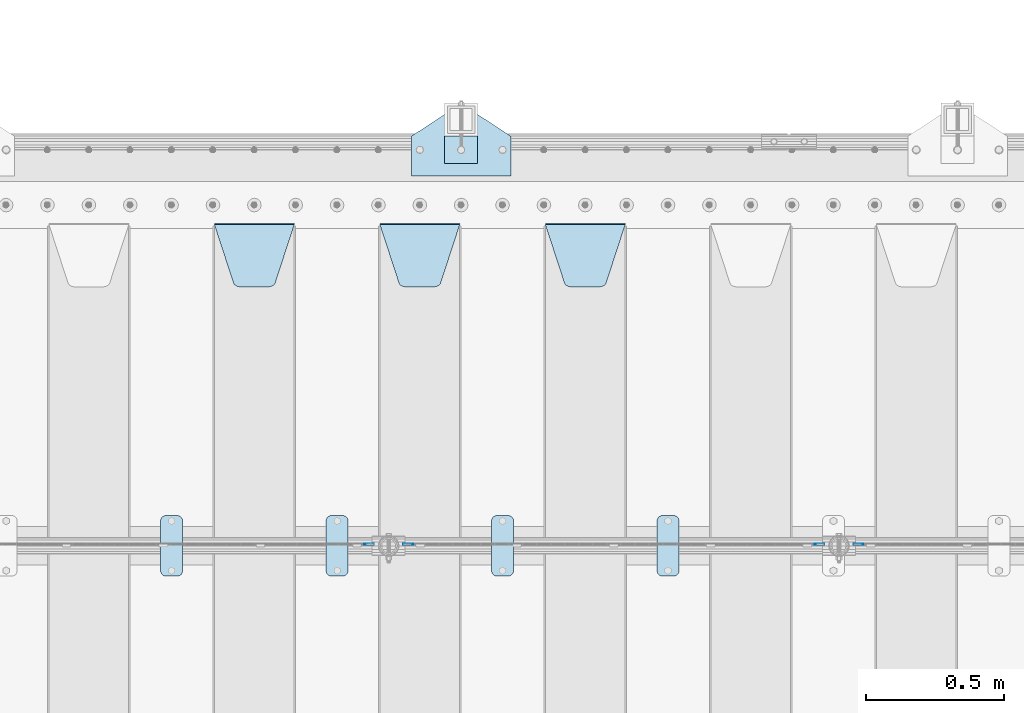
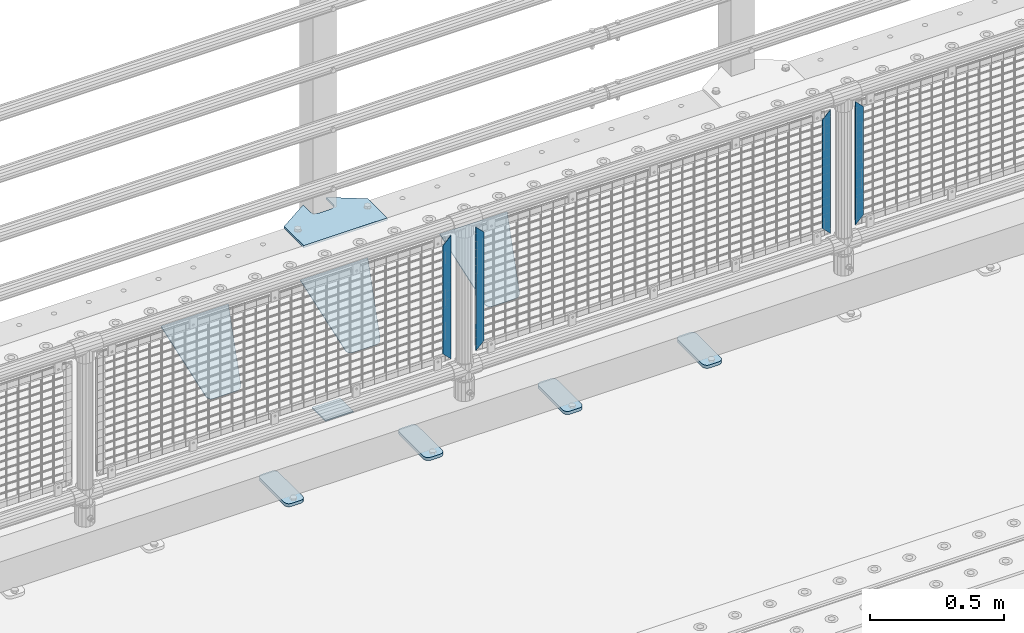
# One storey, part 232 of 270: 13 plates.
"""IFC2X3 building model written with IfcOpenShell, lengths in millimetres."""

import ifcopenshell
import ifcopenshell.guid

model = None  # the IFC model being written
_history = None  # IfcOwnerHistory: only IFC2X3 demands one
_inside = {}  # id of a spatial element -> (the spatial element, [elements in it])
_under = {}  # id of a project, library or spatial element -> (it, [spatial elements below it])
_declared = {}  # id of a project -> (the project, [libraries it declares])
_typed = {}  # id of a type object -> (the type object, [elements of that type])
_made_of = {}  # id of a material, layer set ... -> (it, [elements and type objects made of it])


def new_model(schema):
    """Start an empty IFC model of exactly this schema.

    Asked for "IFC4X3", IfcOpenShell would pick the latest addendum, in which some entities
    have other attributes; the version numbers below select the first issue.
    IFC2X3 requires an IfcOwnerHistory on every rooted entity: one is made here for all.
    """
    global model, _history
    if schema == "IFC4X3":
        model = ifcopenshell.file(schema_version=(4, 3, 0, 0))
    else:
        model = ifcopenshell.file(schema=schema)
    _inside.clear()
    _under.clear()
    _declared.clear()
    _typed.clear()
    _made_of.clear()
    _history = None
    if model.schema == "IFC2X3":
        org = make("IfcOrganization", Name="unknown")
        user = make(
            "IfcPersonAndOrganization",
            ThePerson=make("IfcPerson", FamilyName="unknown"),
            TheOrganization=org,
        )
        app = make(
            "IfcApplication",
            ApplicationDeveloper=org,
            Version="unknown",
            ApplicationFullName="unknown",
            ApplicationIdentifier="unknown",
        )
        _history = make(
            "IfcOwnerHistory",
            OwningUser=user,
            OwningApplication=app,
            ChangeAction="ADDED",
            CreationDate=0,
        )
    return model


def make(cls, **values):
    """One entity of the class cls with the attributes given. An attribute that is None is left unset."""
    return model.create_entity(
        cls, **{name: value for name, value in values.items() if value is not None}
    )


def rooted(cls, **values):
    """An entity with a GlobalId (a new one), such as an element, a storey or a relation."""
    return make(cls, GlobalId=ifcopenshell.guid.new(), OwnerHistory=_history, **values)


def si_unit(unit_type, name, prefix=None):
    """IfcSIUnit, for example si_unit("LENGTHUNIT", "METRE", prefix="MILLI")."""
    return make("IfcSIUnit", UnitType=unit_type, Prefix=prefix, Name=name)


def assignment(units):
    """IfcUnitAssignment: the units of a project."""
    return None if units is None else make("IfcUnitAssignment", Units=units)


def point(xyz):
    """IfcCartesianPoint."""
    return None if xyz is None else make("IfcCartesianPoint", Coordinates=xyz)


def direction(xyz):
    """IfcDirection."""
    return None if xyz is None else make("IfcDirection", DirectionRatios=xyz)


def frame(location, z_axis=None, x_axis=None):
    """IfcAxis2Placement3D, a coordinate frame: its origin and axes. An axis left out is left unset."""
    return make(
        "IfcAxis2Placement3D",
        Location=point(location),
        Axis=direction(z_axis),
        RefDirection=direction(x_axis),
    )


def origin_with_axes():
    """The frame at (0, 0, 0) with the z axis (0, 0, 1) and the x axis (1, 0, 0) written out."""
    return frame((0.0, 0.0, 0.0), z_axis=(0.0, 0.0, 1.0), x_axis=(1.0, 0.0, 0.0))


def place(relative_to, where):
    """IfcLocalPlacement: puts the frame where relative to a parent placement (None: the world)."""
    return make(
        "IfcLocalPlacement", PlacementRelTo=relative_to, RelativePlacement=where
    )


def context(
    kind, dimensions, precision=None, world=None, true_north=None, identifier=None
):
    """IfcGeometricRepresentationContext, for example the 3D "Model" context."""
    return make(
        "IfcGeometricRepresentationContext",
        ContextIdentifier=identifier,
        ContextType=kind,
        CoordinateSpaceDimension=dimensions,
        Precision=precision,
        WorldCoordinateSystem=world,
        TrueNorth=true_north,
    )


def subcontext(parent, identifier, kind, view, scale=None):
    """IfcGeometricRepresentationSubContext, for example "Body" below "Model"."""
    return make(
        "IfcGeometricRepresentationSubContext",
        ContextIdentifier=identifier,
        ContextType=kind,
        ParentContext=parent,
        TargetScale=scale,
        TargetView=view,
    )


def project(units=None, contexts=None):
    """IfcProject with its units and contexts."""
    return rooted(
        "IfcProject",
        Name="project",
        RepresentationContexts=contexts,
        UnitsInContext=assignment(units),
    )


def spatial(cls, under=None, at=None, **own):
    """A site, building, storey or space (cls), placed at a placement, below another one or the project."""
    s = rooted(cls, ObjectPlacement=at, **own)
    if under is not None:
        _under.setdefault(under.id(), (under, []))[1].append(s)
    return s


def faces_of(points, faces, orient=None, outer=None):
    """IfcFace entities. A face is a list of loops; a loop is a list of indices into points, from 0.

    orient and outer hold one flag for each loop. By default every Orientation is true, the
    first loop of a face is its IfcFaceOuterBound and the others are IfcFaceBound.
    """
    made = []
    for i, loops in enumerate(faces):
        bounds = []
        for j, loop in enumerate(loops):
            is_outer = j == 0 if outer is None else outer[i][j]
            bounds.append(
                make(
                    "IfcFaceOuterBound" if is_outer else "IfcFaceBound",
                    Bound=make("IfcPolyLoop", Polygon=[points[k] for k in loop]),
                    Orientation=True if orient is None else orient[i][j],
                )
            )
        made.append(make("IfcFace", Bounds=bounds))
    return made


def faceted_brep(points, faces, orient=None, outer=None, voids=None):
    """IfcFacetedBrep: a solid bounded by flat faces; with voids (closed shells), ...WithVoids."""
    shared = [point(p) for p in points]
    hull = make("IfcClosedShell", CfsFaces=faces_of(shared, faces, orient, outer))
    if voids is None:
        return make("IfcFacetedBrep", Outer=hull)
    return make(
        "IfcFacetedBrepWithVoids",
        Outer=hull,
        Voids=[
            make(cls, CfsFaces=faces_of(shared, fs, o, b)) for cls, fs, o, b in voids
        ],
    )


def shape(context_of_items, identifier, shape_type, items):
    """IfcShapeRepresentation: the items that make up one representation, for example the "Body"."""
    return make(
        "IfcShapeRepresentation",
        ContextOfItems=context_of_items,
        RepresentationIdentifier=identifier,
        RepresentationType=shape_type,
        Items=items,
    )


def material(Name=None, Category=None):
    """IfcMaterial."""
    return make("IfcMaterial", Name=Name, Category=Category)


def made_of(thing, what):
    """Note that an element or type object is made of a material, layer set ...; save() writes the relation."""
    if what is not None:
        _made_of.setdefault(what.id(), (what, []))[1].append(thing)
    return thing


def type_object(cls, material=None, **own):
    """A type object (cls), such as IfcWallType, which elements share."""
    return made_of(rooted(cls, **own), material)


def element(
    cls,
    number,
    at=None,
    inside=None,
    cuts=None,
    type_object=None,
    material=None,
    context=None,
    identifier="Body",
    shape_type=None,
    held_by="IfcProductDefinitionShape",
    body=None,
    shapes=None,
    **own,
):
    """One element of the class cls, such as IfcWall. Its Tag is "e" and its number.

    at: its placement. inside: the storey or other place that contains it. cuts: it is an
    opening in that element (IfcRelVoidsElement). A single representation is given by context,
    identifier, shape_type and body (its items); several are given by shapes. held_by: the class
    of the entity that holds the representations. save() writes the other relations.
    """
    e = rooted(cls, Tag="e%d" % number, ObjectPlacement=at, **own)
    if body is not None:
        shapes = [shape(context, identifier, shape_type, body)]
    if shapes is not None:
        e.Representation = make(held_by, Representations=shapes)
    if inside is not None:
        _inside.setdefault(inside.id(), (inside, []))[1].append(e)
    if cuts is not None:
        rooted(
            "IfcRelVoidsElement", RelatingBuildingElement=cuts, RelatedOpeningElement=e
        )
    if type_object is not None:
        _typed.setdefault(type_object.id(), (type_object, []))[1].append(e)
    return made_of(e, material)


def aggregate(whole, parts):
    """IfcRelAggregates: a whole, such as a stair, and the parts it consists of."""
    return rooted("IfcRelAggregates", RelatingObject=whole, RelatedObjects=parts)


def save(model, path):
    """Write the relations noted so far, then the file.

    IfcRelAggregates (storeys below a building ...), IfcRelContainedInSpatialStructure (elements
    in a storey), IfcRelDefinesByType, IfcRelAssociatesMaterial and IfcRelDeclares: one each for
    every whole, place, type object, material and project.
    """
    for whole, parts in _under.values():
        aggregate(whole, parts)
    for where, things in _inside.values():
        rooted(
            "IfcRelContainedInSpatialStructure",
            RelatedElements=things,
            RelatingStructure=where,
        )
    for kind, things in _typed.values():
        rooted("IfcRelDefinesByType", RelatedObjects=things, RelatingType=kind)
    for what, things in _made_of.values():
        rooted("IfcRelAssociatesMaterial", RelatedObjects=things, RelatingMaterial=what)
    for by, libraries in _declared.values():
        rooted("IfcRelDeclares", RelatingContext=by, RelatedDefinitions=libraries)
    model.write(path)


model = new_model("IFC2X3")

# Units and contexts
model_context = context("Model", 3, precision=1e-05, world=origin_with_axes())
body_context = subcontext(model_context, "Body", "Model", "MODEL_VIEW")
ifc_project = project(units=[si_unit("LENGTHUNIT", "METRE", prefix="MILLI"), si_unit("AREAUNIT", "SQUARE_METRE"), si_unit("VOLUMEUNIT", "CUBIC_METRE"), si_unit("MASSUNIT", "GRAM", prefix="KILO"), si_unit("TIMEUNIT", "SECOND"), si_unit("PLANEANGLEUNIT", "RADIAN"), si_unit("SOLIDANGLEUNIT", "STERADIAN"), si_unit("THERMODYNAMICTEMPERATUREUNIT", "DEGREE_CELSIUS"), si_unit("LUMINOUSINTENSITYUNIT", "LUMEN")], contexts=[model_context])

# Site, building, storey
site_placement = place(None, origin_with_axes())
site = spatial("IfcSite", under=ifc_project, at=site_placement, CompositionType="ELEMENT")
building_placement = place(site_placement, origin_with_axes())
building = spatial("IfcBuilding", under=site, at=building_placement, Name="Standard", CompositionType="ELEMENT")
storey_placement = place(building_placement, origin_with_axes())
storey = spatial("IfcBuildingStorey", under=building, at=storey_placement, Name="Undefined", CompositionType="ELEMENT", Elevation=0.0)

# Plates
ifc_material_1 = material(Name="STEEL/S355J2")
plate_type_1 = type_object("IfcPlateType", PredefinedType="NOTDEFINED")
plate_1_placement = place(storey_placement, frame((3970.0, -14995.0, 5.00000000004911), z_axis=(0.0, 1.0, 0.0), x_axis=(1.0, 0.0, 0.0)))
element("IfcPlate", 1, at=plate_1_placement, inside=storey, type_object=plate_type_1, material=ifc_material_1, context=body_context, shape_type="Brep", body=[
    faceted_brep([(0.0, -5.0, 0.0), (2.31396552408114e-06, -5.0, 145.0), (2.31396552408114e-06, 5.0, 145.0), (0.0, 5.0, 0.0), (130.0, -5.0, 230.0), (130.0, 5.0, 230.0), (130.0, -5.0, 180.0), (130.0, 5.0, 180.0), (130.48036798992, -5.0, 175.122741949597), (130.48036798992, 5.0, 175.122741949597), (131.903011687216, -5.0, 170.432914190873), (131.903011687216, 5.0, 170.432914190873), (134.213259692435, -5.0, 166.11074417451), (134.213259692435, 5.0, 166.11074417451), (137.322330470335, -5.0, 162.322330470337), (137.322330470335, 5.0, 162.322330470337), (141.110744174512, -5.0, 159.213259692437), (141.110744174512, 5.0, 159.213259692437), (145.432914190871, -5.0, 156.903011687218), (145.432914190871, 5.0, 156.903011687218), (150.122741949595, -5.0, 155.48036798992), (150.122741949595, 5.0, 155.48036798992), (155.0, -5.0, 155.0), (155.0, 5.0, 155.0), (205.0, -5.0, 155.0), (205.0, 5.0, 155.0), (209.877258050405, -5.0, 155.48036798992), (209.877258050405, 5.0, 155.48036798992), (214.567085809129, -5.0, 156.903011687218), (214.567085809129, 5.0, 156.903011687218), (218.889255825488, -5.0, 159.213259692437), (218.889255825488, 5.0, 159.213259692437), (222.677669529665, -5.0, 162.322330470337), (222.677669529665, 5.0, 162.322330470337), (225.786740307565, -5.0, 166.11074417451), (225.786740307565, 5.0, 166.11074417451), (228.096988312784, -5.0, 170.432914190873), (228.096988312784, 5.0, 170.432914190873), (229.51963201008, -5.0, 175.122741949597), (229.51963201008, 5.0, 175.122741949597), (230.0, -5.0, 180.0), (230.0, 5.0, 180.0), (230.0, -5.0, 230.0), (230.0, 5.0, 230.0), (360.0, -5.0, 145.0), (360.0, 5.0, 145.0), (360.0, -5.0, -7.27595761418343e-12), (360.0, 5.0, -7.27595761418343e-12)], [[[0, 1, 2, 3]], [[1, 4, 5, 2]], [[4, 6, 7, 5]], [[6, 8, 9, 7]], [[8, 10, 11, 9]], [[10, 12, 13, 11]], [[12, 14, 15, 13]], [[14, 16, 17, 15]], [[16, 18, 19, 17]], [[18, 20, 21, 19]], [[20, 22, 23, 21]], [[22, 24, 25, 23]], [[24, 26, 27, 25]], [[26, 28, 29, 27]], [[28, 30, 31, 29]], [[30, 32, 33, 31]], [[32, 34, 35, 33]], [[34, 36, 37, 35]], [[36, 38, 39, 37]], [[38, 40, 41, 39]], [[40, 42, 43, 41]], [[42, 44, 45, 43]], [[44, 46, 47, 45]], [[46, 0, 3, 47]], [[5, 7, 9, 11, 13, 15, 17, 19, 21, 23, 25, 27, 29, 31, 33, 35, 37, 39, 41, 43, 45, 47, 3, 2]], [[46, 44, 42, 40, 38, 36, 34, 32, 30, 28, 26, 24, 22, 20, 18, 16, 14, 12, 10, 8, 6, 4, 1, 0]]]),
])
plate_type_2 = type_object("IfcPlateType", PredefinedType="NOTDEFINED")
plate_2_placement = place(storey_placement, frame((4090.00000000014, -14949.9999999998, -857.500000000002), z_axis=(0.0, 1.0, 0.0), x_axis=(1.0, 0.0, 0.0)))
element("IfcPlate", 2, at=plate_2_placement, inside=storey, type_object=plate_type_2, material=ifc_material_1, context=body_context, shape_type="Brep", body=[
    faceted_brep([(0.0, -2.5, 0.0), (0.0, -2.5, 100.0), (0.0, 2.5, 100.0), (0.0, 2.5, 0.0), (120.0, -2.5, 100.0), (120.0, 2.5, 100.0), (120.0, -2.5, 0.0), (120.0, 2.5, 0.0)], [[[0, 1, 2, 3]], [[1, 4, 5, 2]], [[4, 6, 7, 5]], [[6, 0, 3, 7]], [[5, 7, 3, 2]], [[6, 4, 1, 0]]]),
])
plate_type_3 = type_object("IfcPlateType", PredefinedType="NOTDEFINED")
plate_3_placement = place(storey_placement, frame((4860.0, -16225.5, 21.0199999999977), z_axis=(1.0, 0.0, 0.0), x_axis=(0.0, -1.0, 0.0)))
element("IfcPlate", 3, at=plate_3_placement, inside=storey, type_object=plate_type_3, material=ifc_material_1, context=body_context, shape_type="Brep", body=[
    faceted_brep([(0.0, -7.0, 20.0), (0.0, -7.0, 60.0), (0.0, 7.0, 60.0), (0.0, 7.0, 20.0), (0.384294391937146, -7.0, 63.9018064403208), (0.384294391937146, 7.0, 63.9018064403208), (1.52240934977453, -7.0, 67.6536686473009), (1.52240934977453, 7.0, 67.6536686473009), (3.37060775395003, -7.0, 71.1114046603907), (3.37060775395003, 7.0, 71.1114046603907), (5.8578643762703, -7.0, 74.1421356237297), (5.8578643762703, 7.0, 74.1421356237297), (8.88859533960931, -7.0, 76.62939224605), (8.88859533960931, 7.0, 76.62939224605), (12.3463313526991, -7.0, 78.4775906502255), (12.3463313526991, 7.0, 78.4775906502255), (16.0981935596792, -7.0, 79.6157056080629), (16.0981935596792, 7.0, 79.6157056080629), (20.0, -7.0, 80.0), (20.0, 7.0, 80.0), (200.0, -7.0, 80.0), (200.0, 7.0, 80.0), (203.901806440321, -7.0, 79.6157056080629), (203.901806440321, 7.0, 79.6157056080629), (207.653668647301, -7.0, 78.4775906502255), (207.653668647301, 7.0, 78.4775906502255), (211.111404660391, -7.0, 76.62939224605), (211.111404660391, 7.0, 76.62939224605), (214.142135623733, -7.0, 74.1421356237297), (214.142135623733, 7.0, 74.1421356237297), (216.629392246054, -7.0, 71.1114046603907), (216.629392246054, 7.0, 71.1114046603907), (218.477590650225, -7.0, 67.6536686473009), (218.477590650225, 7.0, 67.6536686473009), (219.615705608063, -7.0, 63.9018064403208), (219.615705608063, 7.0, 63.9018064403208), (220.0, -7.0, 60.0), (220.0, 7.0, 60.0), (220.0, -7.0, 20.0), (220.0, 7.0, 20.0), (219.615705608063, -7.0, 16.0981935596792), (219.615705608063, 7.0, 16.0981935596792), (218.477590650225, -7.0, 12.3463313526991), (218.477590650225, 7.0, 12.3463313526991), (216.629392246054, -7.0, 8.88859533960931), (216.629392246054, 7.0, 8.88859533960931), (214.142135623733, -7.0, 5.8578643762703), (214.142135623733, 7.0, 5.8578643762703), (211.111404660391, -7.0, 3.37060775395003), (211.111404660391, 7.0, 3.37060775395003), (207.653668647301, -7.0, 1.52240934977453), (207.653668647301, 7.0, 1.52240934977453), (203.901806440321, -7.0, 0.384294391937146), (203.901806440321, 7.0, 0.384294391937146), (200.0, -7.0, 0.0), (200.0, 7.0, 0.0), (20.0, -7.0, 0.0), (20.0, 7.0, 0.0), (16.0981935596792, -7.0, 0.384294391937146), (16.0981935596792, 7.0, 0.384294391937146), (12.3463313526991, -7.0, 1.52240934977453), (12.3463313526991, 7.0, 1.52240934977453), (8.88859533960931, -7.0, 3.37060775395003), (8.88859533960931, 7.0, 3.37060775395003), (5.8578643762703, -7.0, 5.8578643762703), (5.8578643762703, 7.0, 5.8578643762703), (3.37060775395003, -7.0, 8.88859533960931), (3.37060775395003, 7.0, 8.88859533960931), (1.52240934977453, -7.0, 12.3463313526991), (1.52240934977453, 7.0, 12.3463313526991), (0.384294391937146, -7.0, 16.0981935596792), (0.384294391937146, 7.0, 16.0981935596792)], [[[0, 1, 2, 3]], [[1, 4, 5, 2]], [[4, 6, 7, 5]], [[6, 8, 9, 7]], [[8, 10, 11, 9]], [[10, 12, 13, 11]], [[12, 14, 15, 13]], [[14, 16, 17, 15]], [[16, 18, 19, 17]], [[18, 20, 21, 19]], [[20, 22, 23, 21]], [[22, 24, 25, 23]], [[24, 26, 27, 25]], [[26, 28, 29, 27]], [[28, 30, 31, 29]], [[30, 32, 33, 31]], [[32, 34, 35, 33]], [[34, 36, 37, 35]], [[36, 38, 39, 37]], [[38, 40, 41, 39]], [[40, 42, 43, 41]], [[42, 44, 45, 43]], [[44, 46, 47, 45]], [[46, 48, 49, 47]], [[48, 50, 51, 49]], [[50, 52, 53, 51]], [[52, 54, 55, 53]], [[54, 56, 57, 55]], [[56, 58, 59, 57]], [[58, 60, 61, 59]], [[60, 62, 63, 61]], [[62, 64, 65, 63]], [[64, 66, 67, 65]], [[66, 68, 69, 67]], [[68, 70, 71, 69]], [[70, 0, 3, 71]], [[5, 7, 9, 11, 13, 15, 17, 19, 21, 23, 25, 27, 29, 31, 33, 35, 37, 39, 41, 43, 45, 47, 49, 51, 53, 55, 57, 59, 61, 63, 65, 67, 69, 71, 3, 2]], [[70, 68, 66, 64, 62, 60, 58, 56, 54, 52, 50, 48, 46, 44, 42, 40, 38, 36, 34, 32, 30, 28, 26, 24, 22, 20, 18, 16, 14, 12, 10, 8, 6, 4, 1, 0]]]),
])
plate_4_placement = place(storey_placement, frame((4260.0, -16225.5, 21.0199999999977), z_axis=(1.0, 0.0, 0.0), x_axis=(0.0, -1.0, 0.0)))
element("IfcPlate", 4, at=plate_4_placement, inside=storey, type_object=plate_type_3, material=ifc_material_1, context=body_context, shape_type="Brep", body=[
    faceted_brep([(0.0, -7.0, 20.0), (0.0, -7.0, 60.0), (0.0, 7.0, 60.0), (0.0, 7.0, 20.0), (0.384294391937146, -7.0, 63.9018064403208), (0.384294391937146, 7.0, 63.9018064403208), (1.52240934977453, -7.0, 67.6536686473009), (1.52240934977453, 7.0, 67.6536686473009), (3.37060775395003, -7.0, 71.1114046603907), (3.37060775395003, 7.0, 71.1114046603907), (5.8578643762703, -7.0, 74.1421356237297), (5.8578643762703, 7.0, 74.1421356237297), (8.88859533960931, -7.0, 76.62939224605), (8.88859533960931, 7.0, 76.62939224605), (12.3463313526991, -7.0, 78.4775906502255), (12.3463313526991, 7.0, 78.4775906502255), (16.0981935596792, -7.0, 79.6157056080629), (16.0981935596792, 7.0, 79.6157056080629), (20.0, -7.0, 80.0), (20.0, 7.0, 80.0), (200.0, -7.0, 80.0), (200.0, 7.0, 80.0), (203.901806440321, -7.0, 79.6157056080629), (203.901806440321, 7.0, 79.6157056080629), (207.653668647301, -7.0, 78.4775906502255), (207.653668647301, 7.0, 78.4775906502255), (211.111404660391, -7.0, 76.62939224605), (211.111404660391, 7.0, 76.62939224605), (214.142135623733, -7.0, 74.1421356237297), (214.142135623733, 7.0, 74.1421356237297), (216.629392246054, -7.0, 71.1114046603907), (216.629392246054, 7.0, 71.1114046603907), (218.477590650225, -7.0, 67.6536686473009), (218.477590650225, 7.0, 67.6536686473009), (219.615705608063, -7.0, 63.9018064403208), (219.615705608063, 7.0, 63.9018064403208), (220.0, -7.0, 60.0), (220.0, 7.0, 60.0), (220.0, -7.0, 20.0), (220.0, 7.0, 20.0), (219.615705608063, -7.0, 16.0981935596792), (219.615705608063, 7.0, 16.0981935596792), (218.477590650225, -7.0, 12.3463313526991), (218.477590650225, 7.0, 12.3463313526991), (216.629392246054, -7.0, 8.88859533960931), (216.629392246054, 7.0, 8.88859533960931), (214.142135623733, -7.0, 5.8578643762703), (214.142135623733, 7.0, 5.8578643762703), (211.111404660391, -7.0, 3.37060775395003), (211.111404660391, 7.0, 3.37060775395003), (207.653668647301, -7.0, 1.52240934977453), (207.653668647301, 7.0, 1.52240934977453), (203.901806440321, -7.0, 0.384294391937146), (203.901806440321, 7.0, 0.384294391937146), (200.0, -7.0, 0.0), (200.0, 7.0, 0.0), (20.0, -7.0, 0.0), (20.0, 7.0, 0.0), (16.0981935596792, -7.0, 0.384294391937146), (16.0981935596792, 7.0, 0.384294391937146), (12.3463313526991, -7.0, 1.52240934977453), (12.3463313526991, 7.0, 1.52240934977453), (8.88859533960931, -7.0, 3.37060775395003), (8.88859533960931, 7.0, 3.37060775395003), (5.8578643762703, -7.0, 5.8578643762703), (5.8578643762703, 7.0, 5.8578643762703), (3.37060775395003, -7.0, 8.88859533960931), (3.37060775395003, 7.0, 8.88859533960931), (1.52240934977453, -7.0, 12.3463313526991), (1.52240934977453, 7.0, 12.3463313526991), (0.384294391937146, -7.0, 16.0981935596792), (0.384294391937146, 7.0, 16.0981935596792)], [[[0, 1, 2, 3]], [[1, 4, 5, 2]], [[4, 6, 7, 5]], [[6, 8, 9, 7]], [[8, 10, 11, 9]], [[10, 12, 13, 11]], [[12, 14, 15, 13]], [[14, 16, 17, 15]], [[16, 18, 19, 17]], [[18, 20, 21, 19]], [[20, 22, 23, 21]], [[22, 24, 25, 23]], [[24, 26, 27, 25]], [[26, 28, 29, 27]], [[28, 30, 31, 29]], [[30, 32, 33, 31]], [[32, 34, 35, 33]], [[34, 36, 37, 35]], [[36, 38, 39, 37]], [[38, 40, 41, 39]], [[40, 42, 43, 41]], [[42, 44, 45, 43]], [[44, 46, 47, 45]], [[46, 48, 49, 47]], [[48, 50, 51, 49]], [[50, 52, 53, 51]], [[52, 54, 55, 53]], [[54, 56, 57, 55]], [[56, 58, 59, 57]], [[58, 60, 61, 59]], [[60, 62, 63, 61]], [[62, 64, 65, 63]], [[64, 66, 67, 65]], [[66, 68, 69, 67]], [[68, 70, 71, 69]], [[70, 0, 3, 71]], [[5, 7, 9, 11, 13, 15, 17, 19, 21, 23, 25, 27, 29, 31, 33, 35, 37, 39, 41, 43, 45, 47, 49, 51, 53, 55, 57, 59, 61, 63, 65, 67, 69, 71, 3, 2]], [[70, 68, 66, 64, 62, 60, 58, 56, 54, 52, 50, 48, 46, 44, 42, 40, 38, 36, 34, 32, 30, 28, 26, 24, 22, 20, 18, 16, 14, 12, 10, 8, 6, 4, 1, 0]]]),
])
plate_5_placement = place(storey_placement, frame((3660.0, -16225.5, 21.0199999999977), z_axis=(1.0, 0.0, 0.0), x_axis=(0.0, -1.0, 0.0)))
element("IfcPlate", 5, at=plate_5_placement, inside=storey, type_object=plate_type_3, material=ifc_material_1, context=body_context, shape_type="Brep", body=[
    faceted_brep([(0.0, -7.0, 20.0), (0.0, -7.0, 60.0), (0.0, 7.0, 60.0), (0.0, 7.0, 20.0), (0.384294391937146, -7.0, 63.9018064403208), (0.384294391937146, 7.0, 63.9018064403208), (1.52240934977453, -7.0, 67.6536686473009), (1.52240934977453, 7.0, 67.6536686473009), (3.37060775395003, -7.0, 71.1114046603907), (3.37060775395003, 7.0, 71.1114046603907), (5.8578643762703, -7.0, 74.1421356237297), (5.8578643762703, 7.0, 74.1421356237297), (8.88859533960931, -7.0, 76.62939224605), (8.88859533960931, 7.0, 76.62939224605), (12.3463313526991, -7.0, 78.4775906502255), (12.3463313526991, 7.0, 78.4775906502255), (16.0981935596792, -7.0, 79.6157056080629), (16.0981935596792, 7.0, 79.6157056080629), (20.0, -7.0, 80.0), (20.0, 7.0, 80.0), (200.0, -7.0, 80.0), (200.0, 7.0, 80.0), (203.901806440321, -7.0, 79.6157056080629), (203.901806440321, 7.0, 79.6157056080629), (207.653668647301, -7.0, 78.4775906502255), (207.653668647301, 7.0, 78.4775906502255), (211.111404660391, -7.0, 76.62939224605), (211.111404660391, 7.0, 76.62939224605), (214.142135623733, -7.0, 74.1421356237297), (214.142135623733, 7.0, 74.1421356237297), (216.629392246054, -7.0, 71.1114046603907), (216.629392246054, 7.0, 71.1114046603907), (218.477590650225, -7.0, 67.6536686473009), (218.477590650225, 7.0, 67.6536686473009), (219.615705608063, -7.0, 63.9018064403208), (219.615705608063, 7.0, 63.9018064403208), (220.0, -7.0, 60.0), (220.0, 7.0, 60.0), (220.0, -7.0, 20.0), (220.0, 7.0, 20.0), (219.615705608063, -7.0, 16.0981935596792), (219.615705608063, 7.0, 16.0981935596792), (218.477590650225, -7.0, 12.3463313526991), (218.477590650225, 7.0, 12.3463313526991), (216.629392246054, -7.0, 8.88859533960931), (216.629392246054, 7.0, 8.88859533960931), (214.142135623733, -7.0, 5.8578643762703), (214.142135623733, 7.0, 5.8578643762703), (211.111404660391, -7.0, 3.37060775395003), (211.111404660391, 7.0, 3.37060775395003), (207.653668647301, -7.0, 1.52240934977453), (207.653668647301, 7.0, 1.52240934977453), (203.901806440321, -7.0, 0.384294391937146), (203.901806440321, 7.0, 0.384294391937146), (200.0, -7.0, 0.0), (200.0, 7.0, 0.0), (20.0, -7.0, 0.0), (20.0, 7.0, 0.0), (16.0981935596792, -7.0, 0.384294391937146), (16.0981935596792, 7.0, 0.384294391937146), (12.3463313526991, -7.0, 1.52240934977453), (12.3463313526991, 7.0, 1.52240934977453), (8.88859533960931, -7.0, 3.37060775395003), (8.88859533960931, 7.0, 3.37060775395003), (5.8578643762703, -7.0, 5.8578643762703), (5.8578643762703, 7.0, 5.8578643762703), (3.37060775395003, -7.0, 8.88859533960931), (3.37060775395003, 7.0, 8.88859533960931), (1.52240934977453, -7.0, 12.3463313526991), (1.52240934977453, 7.0, 12.3463313526991), (0.384294391937146, -7.0, 16.0981935596792), (0.384294391937146, 7.0, 16.0981935596792)], [[[0, 1, 2, 3]], [[1, 4, 5, 2]], [[4, 6, 7, 5]], [[6, 8, 9, 7]], [[8, 10, 11, 9]], [[10, 12, 13, 11]], [[12, 14, 15, 13]], [[14, 16, 17, 15]], [[16, 18, 19, 17]], [[18, 20, 21, 19]], [[20, 22, 23, 21]], [[22, 24, 25, 23]], [[24, 26, 27, 25]], [[26, 28, 29, 27]], [[28, 30, 31, 29]], [[30, 32, 33, 31]], [[32, 34, 35, 33]], [[34, 36, 37, 35]], [[36, 38, 39, 37]], [[38, 40, 41, 39]], [[40, 42, 43, 41]], [[42, 44, 45, 43]], [[44, 46, 47, 45]], [[46, 48, 49, 47]], [[48, 50, 51, 49]], [[50, 52, 53, 51]], [[52, 54, 55, 53]], [[54, 56, 57, 55]], [[56, 58, 59, 57]], [[58, 60, 61, 59]], [[60, 62, 63, 61]], [[62, 64, 65, 63]], [[64, 66, 67, 65]], [[66, 68, 69, 67]], [[68, 70, 71, 69]], [[70, 0, 3, 71]], [[5, 7, 9, 11, 13, 15, 17, 19, 21, 23, 25, 27, 29, 31, 33, 35, 37, 39, 41, 43, 45, 47, 49, 51, 53, 55, 57, 59, 61, 63, 65, 67, 69, 71, 3, 2]], [[70, 68, 66, 64, 62, 60, 58, 56, 54, 52, 50, 48, 46, 44, 42, 40, 38, 36, 34, 32, 30, 28, 26, 24, 22, 20, 18, 16, 14, 12, 10, 8, 6, 4, 1, 0]]]),
])
plate_6_placement = place(storey_placement, frame((3060.0, -16225.5, 21.0199999999977), z_axis=(1.0, 0.0, 0.0), x_axis=(0.0, -1.0, 0.0)))
element("IfcPlate", 6, at=plate_6_placement, inside=storey, type_object=plate_type_3, material=ifc_material_1, context=body_context, shape_type="Brep", body=[
    faceted_brep([(0.0, -7.0, 20.0), (0.0, -7.0, 60.0), (0.0, 7.0, 60.0), (0.0, 7.0, 20.0), (0.384294391937146, -7.0, 63.9018064403208), (0.384294391937146, 7.0, 63.9018064403208), (1.52240934977453, -7.0, 67.6536686473009), (1.52240934977453, 7.0, 67.6536686473009), (3.37060775395003, -7.0, 71.1114046603907), (3.37060775395003, 7.0, 71.1114046603907), (5.8578643762703, -7.0, 74.1421356237297), (5.8578643762703, 7.0, 74.1421356237297), (8.88859533960931, -7.0, 76.62939224605), (8.88859533960931, 7.0, 76.62939224605), (12.3463313526991, -7.0, 78.4775906502255), (12.3463313526991, 7.0, 78.4775906502255), (16.0981935596792, -7.0, 79.6157056080629), (16.0981935596792, 7.0, 79.6157056080629), (20.0, -7.0, 80.0), (20.0, 7.0, 80.0), (200.0, -7.0, 80.0), (200.0, 7.0, 80.0), (203.901806440321, -7.0, 79.6157056080629), (203.901806440321, 7.0, 79.6157056080629), (207.653668647301, -7.0, 78.4775906502255), (207.653668647301, 7.0, 78.4775906502255), (211.111404660391, -7.0, 76.62939224605), (211.111404660391, 7.0, 76.62939224605), (214.142135623733, -7.0, 74.1421356237297), (214.142135623733, 7.0, 74.1421356237297), (216.629392246054, -7.0, 71.1114046603907), (216.629392246054, 7.0, 71.1114046603907), (218.477590650225, -7.0, 67.6536686473009), (218.477590650225, 7.0, 67.6536686473009), (219.615705608063, -7.0, 63.9018064403208), (219.615705608063, 7.0, 63.9018064403208), (220.0, -7.0, 60.0), (220.0, 7.0, 60.0), (220.0, -7.0, 20.0), (220.0, 7.0, 20.0), (219.615705608063, -7.0, 16.0981935596792), (219.615705608063, 7.0, 16.0981935596792), (218.477590650225, -7.0, 12.3463313526991), (218.477590650225, 7.0, 12.3463313526991), (216.629392246054, -7.0, 8.88859533960931), (216.629392246054, 7.0, 8.88859533960931), (214.142135623733, -7.0, 5.8578643762703), (214.142135623733, 7.0, 5.8578643762703), (211.111404660391, -7.0, 3.37060775395003), (211.111404660391, 7.0, 3.37060775395003), (207.653668647301, -7.0, 1.52240934977453), (207.653668647301, 7.0, 1.52240934977453), (203.901806440321, -7.0, 0.384294391937146), (203.901806440321, 7.0, 0.384294391937146), (200.0, -7.0, 0.0), (200.0, 7.0, 0.0), (20.0, -7.0, 0.0), (20.0, 7.0, 0.0), (16.0981935596792, -7.0, 0.384294391937146), (16.0981935596792, 7.0, 0.384294391937146), (12.3463313526991, -7.0, 1.52240934977453), (12.3463313526991, 7.0, 1.52240934977453), (8.88859533960931, -7.0, 3.37060775395003), (8.88859533960931, 7.0, 3.37060775395003), (5.8578643762703, -7.0, 5.8578643762703), (5.8578643762703, 7.0, 5.8578643762703), (3.37060775395003, -7.0, 8.88859533960931), (3.37060775395003, 7.0, 8.88859533960931), (1.52240934977453, -7.0, 12.3463313526991), (1.52240934977453, 7.0, 12.3463313526991), (0.384294391937146, -7.0, 16.0981935596792), (0.384294391937146, 7.0, 16.0981935596792)], [[[0, 1, 2, 3]], [[1, 4, 5, 2]], [[4, 6, 7, 5]], [[6, 8, 9, 7]], [[8, 10, 11, 9]], [[10, 12, 13, 11]], [[12, 14, 15, 13]], [[14, 16, 17, 15]], [[16, 18, 19, 17]], [[18, 20, 21, 19]], [[20, 22, 23, 21]], [[22, 24, 25, 23]], [[24, 26, 27, 25]], [[26, 28, 29, 27]], [[28, 30, 31, 29]], [[30, 32, 33, 31]], [[32, 34, 35, 33]], [[34, 36, 37, 35]], [[36, 38, 39, 37]], [[38, 40, 41, 39]], [[40, 42, 43, 41]], [[42, 44, 45, 43]], [[44, 46, 47, 45]], [[46, 48, 49, 47]], [[48, 50, 51, 49]], [[50, 52, 53, 51]], [[52, 54, 55, 53]], [[54, 56, 57, 55]], [[56, 58, 59, 57]], [[58, 60, 61, 59]], [[60, 62, 63, 61]], [[62, 64, 65, 63]], [[64, 66, 67, 65]], [[66, 68, 69, 67]], [[68, 70, 71, 69]], [[70, 0, 3, 71]], [[5, 7, 9, 11, 13, 15, 17, 19, 21, 23, 25, 27, 29, 31, 33, 35, 37, 39, 41, 43, 45, 47, 49, 51, 53, 55, 57, 59, 61, 63, 65, 67, 69, 71, 3, 2]], [[70, 68, 66, 64, 62, 60, 58, 56, 54, 52, 50, 48, 46, 44, 42, 40, 38, 36, 34, 32, 30, 28, 26, 24, 22, 20, 18, 16, 14, 12, 10, 8, 6, 4, 1, 0]]]),
])
ifc_material_2 = material(Name="STEEL/S355N")
plate_type_4 = type_object("IfcPlateType", PredefinedType="NOTDEFINED")
plate_7_placement = place(storey_placement, frame((4455.0, -15168.2322330441, -1.76776695296576), z_axis=(0.0, -0.707106781186548, -0.707106781186547), x_axis=(1.0, 0.0, 0.0)))
element("IfcPlate", 7, at=plate_7_placement, inside=storey, type_object=plate_type_4, material=ifc_material_2, context=body_context, shape_type="Brep", body=[
    faceted_brep([(0.0, -2.5, 0.0), (69.345504679477, -2.5, 300.171731424831), (69.345504679477, 2.5, 300.171731424831), (0.0, 2.5, 0.0), (70.9274061199576, -2.5, 304.8974424154), (70.9274061199576, 2.5, 304.8974424154), (73.3818627772307, -2.49999999999818, 309.234538108527), (73.3818627772307, 2.50000000000182, 309.234538108527), (76.6187032999551, -2.5, 313.023683126103), (76.6187032999551, 2.5, 313.023683126103), (80.5190132704993, -2.5, 316.125672595372), (80.5190132704993, 2.50000000000182, 316.125672595372), (84.9395038596849, -2.49999999999818, 318.426546230476), (84.9395038596849, 2.5, 318.426546230476), (89.7177759439219, -2.49999999999818, 319.841774983275), (89.7177759439219, 2.50000000000182, 319.841774983275), (94.678286292652, -2.5, 320.319366455078), (94.678286292652, 2.5, 320.319366455078), (195.321713707348, -2.5, 320.319366455078), (195.321713707348, 2.5, 320.319366455078), (200.282224056078, -2.49999999999818, 319.841774983275), (200.282224056078, 2.50000000000182, 319.841774983275), (205.060496140315, -2.5, 318.426546230476), (205.060496140315, 2.5, 318.426546230476), (209.480986729501, -2.5, 316.12567259537), (209.480986729501, 2.50000000000182, 316.12567259537), (213.381296700045, -2.5, 313.023683126103), (213.381296700045, 2.5, 313.023683126103), (216.618137222769, -2.49999999999818, 309.234538108525), (216.618137222769, 2.50000000000182, 309.234538108527), (219.072593880042, -2.49999999999818, 304.897442415398), (219.072593880042, 2.50000000000182, 304.897442415397), (220.654495320523, -2.5, 300.171731424831), (220.654495320523, 2.5, 300.171731424831), (290.0, -2.49999999999818, 0.0), (290.0, 2.5, 0.0)], [[[0, 1, 2, 3]], [[1, 4, 5, 2]], [[4, 6, 7, 5]], [[6, 8, 9, 7]], [[8, 10, 11, 9]], [[10, 12, 13, 11]], [[12, 14, 15, 13]], [[14, 16, 17, 15]], [[16, 18, 19, 17]], [[18, 20, 21, 19]], [[20, 22, 23, 21]], [[22, 24, 25, 23]], [[24, 26, 27, 25]], [[26, 28, 29, 27]], [[28, 30, 31, 29]], [[30, 32, 33, 31]], [[32, 34, 35, 33]], [[34, 0, 3, 35]], [[5, 7, 9, 11, 13, 15, 17, 19, 21, 23, 25, 27, 29, 31, 33, 35, 3, 2]], [[34, 32, 30, 28, 26, 24, 22, 20, 18, 16, 14, 12, 10, 8, 6, 4, 1, 0]]]),
])
plate_8_placement = place(storey_placement, frame((3855.0, -15168.2322330441, -1.76776695296576), z_axis=(0.0, -0.707106781186548, -0.707106781186547), x_axis=(1.0, 0.0, 0.0)))
element("IfcPlate", 8, at=plate_8_placement, inside=storey, type_object=plate_type_4, material=ifc_material_2, context=body_context, shape_type="Brep", body=[
    faceted_brep([(0.0, -2.5, 0.0), (69.345504679477, -2.5, 300.171731424831), (69.345504679477, 2.5, 300.171731424831), (0.0, 2.5, 0.0), (70.9274061199576, -2.5, 304.8974424154), (70.9274061199576, 2.5, 304.8974424154), (73.3818627772307, -2.49999999999818, 309.234538108527), (73.3818627772307, 2.50000000000182, 309.234538108527), (76.6187032999551, -2.5, 313.023683126103), (76.6187032999551, 2.5, 313.023683126103), (80.5190132704993, -2.5, 316.125672595372), (80.5190132704993, 2.50000000000182, 316.125672595372), (84.9395038596849, -2.49999999999818, 318.426546230476), (84.9395038596849, 2.5, 318.426546230476), (89.7177759439219, -2.49999999999818, 319.841774983275), (89.7177759439219, 2.50000000000182, 319.841774983275), (94.678286292652, -2.5, 320.319366455078), (94.678286292652, 2.5, 320.319366455078), (195.321713707348, -2.5, 320.319366455078), (195.321713707348, 2.5, 320.319366455078), (200.282224056078, -2.49999999999818, 319.841774983275), (200.282224056078, 2.50000000000182, 319.841774983275), (205.060496140315, -2.5, 318.426546230476), (205.060496140315, 2.5, 318.426546230476), (209.480986729501, -2.5, 316.12567259537), (209.480986729501, 2.50000000000182, 316.12567259537), (213.381296700045, -2.5, 313.023683126103), (213.381296700045, 2.5, 313.023683126103), (216.618137222769, -2.49999999999818, 309.234538108525), (216.618137222769, 2.50000000000182, 309.234538108527), (219.072593880042, -2.49999999999818, 304.897442415398), (219.072593880042, 2.50000000000182, 304.897442415397), (220.654495320523, -2.5, 300.171731424831), (220.654495320523, 2.5, 300.171731424831), (290.0, -2.49999999999818, 0.0), (290.0, 2.5, 0.0)], [[[0, 1, 2, 3]], [[1, 4, 5, 2]], [[4, 6, 7, 5]], [[6, 8, 9, 7]], [[8, 10, 11, 9]], [[10, 12, 13, 11]], [[12, 14, 15, 13]], [[14, 16, 17, 15]], [[16, 18, 19, 17]], [[18, 20, 21, 19]], [[20, 22, 23, 21]], [[22, 24, 25, 23]], [[24, 26, 27, 25]], [[26, 28, 29, 27]], [[28, 30, 31, 29]], [[30, 32, 33, 31]], [[32, 34, 35, 33]], [[34, 0, 3, 35]], [[5, 7, 9, 11, 13, 15, 17, 19, 21, 23, 25, 27, 29, 31, 33, 35, 3, 2]], [[34, 32, 30, 28, 26, 24, 22, 20, 18, 16, 14, 12, 10, 8, 6, 4, 1, 0]]]),
])
plate_9_placement = place(storey_placement, frame((3255.0, -15168.2322330441, -1.76776695296576), z_axis=(0.0, -0.707106781186548, -0.707106781186547), x_axis=(1.0, 0.0, 0.0)))
element("IfcPlate", 9, at=plate_9_placement, inside=storey, type_object=plate_type_4, material=ifc_material_2, context=body_context, shape_type="Brep", body=[
    faceted_brep([(0.0, -2.5, 0.0), (69.345504679477, -2.5, 300.171731424831), (69.345504679477, 2.5, 300.171731424831), (0.0, 2.5, 0.0), (70.9274061199576, -2.5, 304.8974424154), (70.9274061199576, 2.5, 304.8974424154), (73.3818627772307, -2.49999999999818, 309.234538108527), (73.3818627772307, 2.50000000000182, 309.234538108527), (76.6187032999551, -2.5, 313.023683126103), (76.6187032999551, 2.5, 313.023683126103), (80.5190132704993, -2.5, 316.125672595372), (80.5190132704993, 2.50000000000182, 316.125672595372), (84.9395038596849, -2.49999999999818, 318.426546230476), (84.9395038596849, 2.5, 318.426546230476), (89.7177759439219, -2.49999999999818, 319.841774983275), (89.7177759439219, 2.50000000000182, 319.841774983275), (94.678286292652, -2.5, 320.319366455078), (94.678286292652, 2.5, 320.319366455078), (195.321713707348, -2.5, 320.319366455078), (195.321713707348, 2.5, 320.319366455078), (200.282224056078, -2.49999999999818, 319.841774983275), (200.282224056078, 2.50000000000182, 319.841774983275), (205.060496140315, -2.5, 318.426546230476), (205.060496140315, 2.5, 318.426546230476), (209.480986729501, -2.5, 316.12567259537), (209.480986729501, 2.50000000000182, 316.12567259537), (213.381296700045, -2.5, 313.023683126103), (213.381296700045, 2.5, 313.023683126103), (216.618137222769, -2.49999999999818, 309.234538108525), (216.618137222769, 2.50000000000182, 309.234538108527), (219.072593880042, -2.49999999999818, 304.897442415398), (219.072593880042, 2.50000000000182, 304.897442415397), (220.654495320523, -2.5, 300.171731424831), (220.654495320523, 2.5, 300.171731424831), (290.0, -2.49999999999818, 0.0), (290.0, 2.5, 0.0)], [[[0, 1, 2, 3]], [[1, 4, 5, 2]], [[4, 6, 7, 5]], [[6, 8, 9, 7]], [[8, 10, 11, 9]], [[10, 12, 13, 11]], [[12, 14, 15, 13]], [[14, 16, 17, 15]], [[16, 18, 19, 17]], [[18, 20, 21, 19]], [[20, 22, 23, 21]], [[22, 24, 25, 23]], [[24, 26, 27, 25]], [[26, 28, 29, 27]], [[28, 30, 31, 29]], [[30, 32, 33, 31]], [[32, 34, 35, 33]], [[34, 0, 3, 35]], [[5, 7, 9, 11, 13, 15, 17, 19, 21, 23, 25, 27, 29, 31, 33, 35, 3, 2]], [[34, 32, 30, 28, 26, 24, 22, 20, 18, 16, 14, 12, 10, 8, 6, 4, 1, 0]]]),
])
ifc_material_3 = material(Name="Misc_Undefined")
plate_type_5 = type_object("IfcPlateType", PredefinedType="NOTDEFINED")
for number, where, z_axis, x_axis in (
    (10, (5608.50971354097, -16329.5, 879.519963133601), (-0.707008801899319, 0.0, -0.707204746899291), (-0.707204746899302, 0.0, 0.707008801899308)),
    (11, (3975.50971354097, -16329.5, 879.519963133601), (-0.707008801899319, 0.0, -0.707204746899291), (-0.707204746899302, 0.0, 0.707008801899308)),
):
    element("IfcPlate", number, at=place(storey_placement, frame(where, z_axis=z_axis, x_axis=x_axis)), inside=storey, type_object=plate_type_5, material=ifc_material_3, context=body_context, shape_type="Brep", body=[
        faceted_brep([(0.0, -1.5, 0.0), (-348.552185058599, -1.5, 348.655029296877), (-348.552185058599, 1.5, 348.655029296877), (0.0, 1.5, 0.0), (-348.544891357427, -1.5, 398.152496337894), (-348.544891357427, 1.5, 398.152496337894), (49.50439453125, -1.5, 8.00355337560177e-11), (49.50439453125, 1.5, 8.00355337560177e-11)], [[[0, 1, 2, 3]], [[1, 4, 5, 2]], [[4, 6, 7, 5]], [[6, 0, 3, 7]], [[5, 7, 3, 2]], [[6, 4, 1, 0]]]),
    ])
for number, where, z_axis, x_axis in (
    (12, (5431.49968748361, -16329.5, 879.52), (0.707103624179499, 0.0, -0.707109938179501), (0.707109938179513, 0.0, 0.707103624179487)),
    (13, (3798.49968748361, -16329.5, 879.52), (0.707103624179499, 0.0, -0.707109938179501), (0.707109938179513, 0.0, 0.707103624179487)),
):
    element("IfcPlate", number, at=place(storey_placement, frame(where, z_axis=z_axis, x_axis=x_axis)), inside=storey, type_object=plate_type_5, material=ifc_material_3, context=body_context, shape_type="Brep", body=[
        faceted_brep([(0.0, -1.5, 0.0), (-348.605163574224, -1.5, 348.602081298828), (-348.605163574224, 1.5, 348.602081298828), (0.0, 1.5, 0.0), (-348.605163574226, -1.5, 398.099334716795), (-348.605163574226, 1.5, 398.099334716795), (49.4976959228497, -1.5, -7.27595761418343e-12), (49.4976959228497, 1.5, -7.27595761418343e-12)], [[[0, 1, 2, 3]], [[1, 4, 5, 2]], [[4, 6, 7, 5]], [[6, 0, 3, 7]], [[5, 7, 3, 2]], [[6, 4, 1, 0]]]),
    ])

save(model, "model.ifc")
